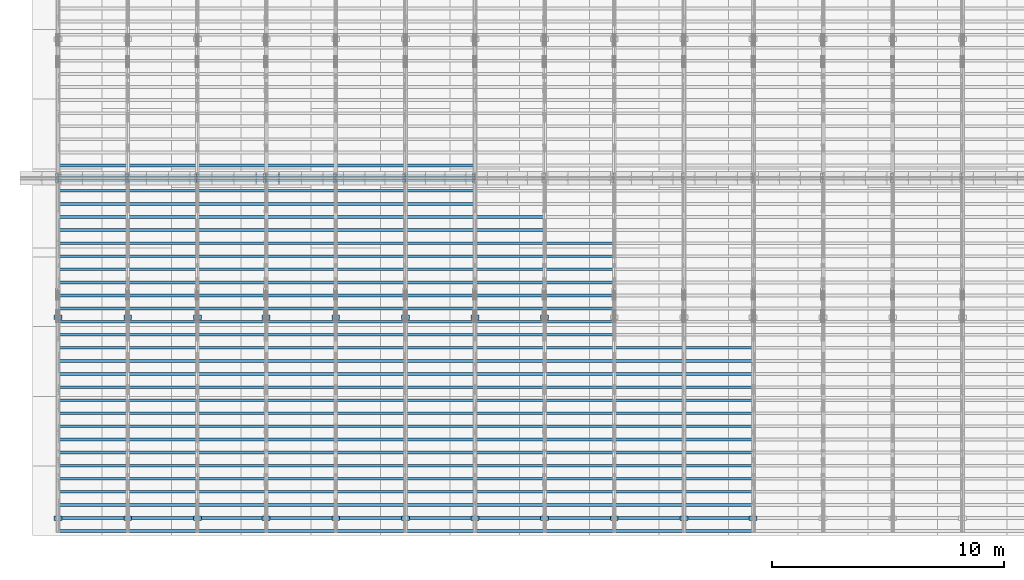
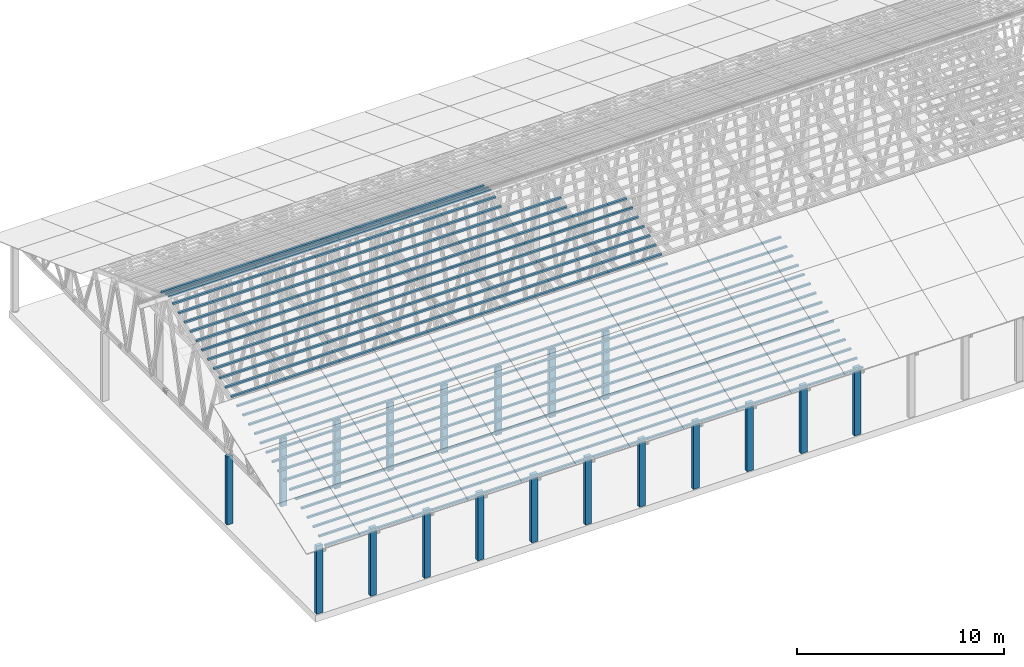
# One storey, part 1 of 189: 277 columns.
"""IFC2X3 building model written with IfcOpenShell, lengths in millimetres."""

from ifc_helpers import new_model, entity, si_unit, converted_unit, derived_unit, direction, frame, frame_2d, origin, origin_2d_with_axis, place, context, subcontext, project, spatial, rectangle, extrude, boolean, source, transform, mapped, material, type_object, type_shapes, element, save


model = new_model("IFC2X3")

# Units and contexts
model_context = context("Model", 3, precision=0.01, world=origin(), true_north=direction((6.12303176911189e-17, 1.0)))
body_context = subcontext(model_context, "Body", "Model", "MODEL_VIEW")
ifc_project = project(units=[si_unit("LENGTHUNIT", "METRE", prefix="MILLI"), si_unit("AREAUNIT", "SQUARE_METRE"), si_unit("VOLUMEUNIT", "CUBIC_METRE"), converted_unit("PLANEANGLEUNIT", "DEGREE", entity("IfcRatioMeasure", 0.0174532925199433), si_unit("PLANEANGLEUNIT", "RADIAN"), dimensions=[0, 0, 0, 0, 0, 0, 0]), si_unit("MASSUNIT", "GRAM", prefix="KILO"), derived_unit("MASSDENSITYUNIT", [(si_unit("MASSUNIT", "GRAM", prefix="KILO"), 1), (si_unit("LENGTHUNIT", "METRE"), -3)]), si_unit("TIMEUNIT", "SECOND"), si_unit("FREQUENCYUNIT", "HERTZ"), si_unit("THERMODYNAMICTEMPERATUREUNIT", "DEGREE_CELSIUS"), derived_unit("THERMALTRANSMITTANCEUNIT", [(si_unit("MASSUNIT", "GRAM", prefix="KILO"), 1), (si_unit("THERMODYNAMICTEMPERATUREUNIT", "KELVIN"), -1), (si_unit("TIMEUNIT", "SECOND"), -3)]), derived_unit("VOLUMETRICFLOWRATEUNIT", [(si_unit("LENGTHUNIT", "METRE"), 3), (si_unit("TIMEUNIT", "SECOND"), -1)]), si_unit("ELECTRICCURRENTUNIT", "AMPERE"), si_unit("ELECTRICVOLTAGEUNIT", "VOLT"), si_unit("POWERUNIT", "WATT"), si_unit("FORCEUNIT", "NEWTON"), si_unit("ILLUMINANCEUNIT", "LUX"), si_unit("LUMINOUSFLUXUNIT", "LUMEN"), si_unit("LUMINOUSINTENSITYUNIT", "CANDELA"), derived_unit("USERDEFINED", [(si_unit("MASSUNIT", "GRAM", prefix="KILO"), -1), (si_unit("LENGTHUNIT", "METRE"), -2), (si_unit("TIMEUNIT", "SECOND"), 3), (si_unit("LUMINOUSFLUXUNIT", "LUMEN"), 1)]), derived_unit("LINEARVELOCITYUNIT", [(si_unit("LENGTHUNIT", "METRE"), 1), (si_unit("TIMEUNIT", "SECOND"), -1)]), si_unit("PRESSUREUNIT", "PASCAL"), derived_unit("USERDEFINED", [(si_unit("LENGTHUNIT", "METRE"), -2), (si_unit("MASSUNIT", "GRAM", prefix="KILO"), 1), (si_unit("TIMEUNIT", "SECOND"), -2)])], contexts=[model_context])

# Site, building, storey
site_placement = place(None, origin())
site = spatial("IfcSite", under=ifc_project, at=site_placement, CompositionType="ELEMENT")
building_placement = place(site_placement, origin())
building = spatial("IfcBuilding", under=site, at=building_placement, CompositionType="ELEMENT")
storey_placement = place(building_placement, origin())
storey = spatial("IfcBuildingStorey", under=building, at=storey_placement, Name="Default", CompositionType="ELEMENT", Elevation=0.0)

# Columns
ifc_material_1 = material(Name="2")
column_type_1 = type_object("IfcColumnType", Name="100x70", PredefinedType="COLUMN")
shared_shape_1 = source(origin(), body_context, "Body", "CSG", [
    boolean("DIFFERENCE", extrude(rectangle(XDim=2998.26294985256, YDim=117.910672112436, at=frame_2d((0.0, -7.105427357601e-15), x_axis=(1.0, 0.0))), frame((1499.13147492628, 146.833369190677, -28.6286403914047)), (0.0, 0.0, 1.0), 99.9804977897746), extrude(rectangle(XDim=70.0000000018648, YDim=100.00000000027, at=frame_2d((3.5527136788005e-15, 3.5527136788005e-15), x_axis=(0.0, 1.0))), frame((2998.26294985256, 146.833369190677, 21.3616085034827), z_axis=(1.0, 0.0, 0.0), x_axis=(0.0, 0.939692620784201, -0.34202014333036)), (0.0, 0.0, -1.0), 2998.26294985256)),
])
type_shapes(column_type_1, [shared_shape_1])
for number, where, name in (
    (1, (15233.4741002949, 15149.371280703, 5585.64342365955), "H_28_35_gradi:100x70"),
    (2, (15233.4741002949, 14712.1220107287, 5744.78914288479), "H_28_35_gradi:100x70"),
    (3, (12231.7370501475, 15149.371280703, 5585.64342365955), "H_28_35_gradi:100x70"),
    (4, (12231.7370501475, 14712.1220107288, 5744.78914288479), "H_28_35_gradi:100x70"),
    (5, (9233.47410029491, 15149.371280703, 5585.64342365955), "H_28_35_gradi:100x70"),
    (6, (9233.47410029491, 14712.1220107288, 5744.78914288479), "H_28_35_gradi:100x70"),
    (7, (6235.21115044234, 15149.371280703, 5585.64342365955), "H_28_35_gradi:100x70"),
    (8, (6235.21115044234, 14712.1220107288, 5744.78914288479), "H_28_35_gradi:100x70"),
    (9, (3266.73705014749, 15149.371280703, 5585.64342365955), "H_28_35_gradi:100x70"),
    (10, (3266.73705014749, 14712.1220107288, 5744.78914288479), "H_28_35_gradi:100x70"),
    (11, (268.474100294913, 15149.371280703, 5585.64342365955), "H_28_35_gradi:100x70"),
    (12, (268.474100294913, 14712.1220107288, 5744.78914288479), "H_28_35_gradi:100x70"),
):
    element("IfcColumn", number, at=place(storey_placement, frame(where)), inside=storey, type_object=column_type_1, material=ifc_material_1, Name=name, ObjectType="H_28_35_gradi:100x70", context=body_context, shape_type="MappedRepresentation", body=[
        mapped(shared_shape_1, transform((0.0, 0.0, 0.0), scale=1.0)),
    ])
column_type_2 = type_object("IfcColumnType", Name="100x70", PredefinedType="COLUMN")
shared_shape_2 = source(origin(), body_context, "Body", "CSG", [
    boolean("DIFFERENCE", extrude(rectangle(XDim=2998.26294985257, YDim=117.910672112436, at=frame_2d((0.0, 7.105427357601e-15), x_axis=(1.0, 0.0))), frame((1499.13147492629, -146.833369190677, -28.6286403914047)), (0.0, 0.0, 1.0), 99.9804977897746), extrude(rectangle(XDim=70.0000000018648, YDim=100.00000000027, at=frame_2d((3.5527136788005e-15, 3.5527136788005e-15), x_axis=(0.0, 1.0))), frame((0.0, -146.833369190677, 21.3616085034827), z_axis=(-1.0, 0.0, 0.0), x_axis=(0.0, -0.939692620784201, -0.34202014333036)), (0.0, 0.0, -1.0), 2998.26294985257)),
])
type_shapes(column_type_2, [shared_shape_2])
for number, where, name in (
    (13, (27231.7370501474, 255.239495234009, 455.341273776488), "H_28_35_gradi:100x70"),
    (14, (27231.7370501474, 819.055067706269, 660.553359769929), "H_28_35_gradi:100x70"),
    (15, (27231.7370501474, 1382.87064017781, 865.765445765329), "H_28_35_gradi:100x70"),
    (16, (27231.7370501474, 1946.68621264935, 1070.97753176073), "H_28_35_gradi:100x70"),
    (17, (27231.7370501474, 2510.50178512089, 1276.18961775613), "H_28_35_gradi:100x70"),
    (18, (27231.7370501474, 3074.31735759244, 1481.40170375153), "H_28_35_gradi:100x70"),
    (19, (27231.7370501474, 3638.13293006398, 1686.61378974693), "H_28_35_gradi:100x70"),
    (20, (27231.7370501474, 4201.94850253552, 1891.82587574233), "H_28_35_gradi:100x70"),
    (21, (27231.7370501474, 4765.76407500707, 2097.03796173773), "H_28_35_gradi:100x70"),
    (22, (27231.7370501474, 5329.57964747861, 2302.25004773314), "H_28_35_gradi:100x70"),
    (23, (27231.7370501474, 5893.39521995016, 2507.46213372854), "H_28_35_gradi:100x70"),
    (24, (27231.7370501474, 6457.2107924217, 2712.67421972394), "H_28_35_gradi:100x70"),
    (25, (27231.7370501474, 7021.02636489325, 2917.88630571934), "H_28_35_gradi:100x70"),
    (26, (27231.7370501474, 7584.84193736479, 3123.09839171474), "H_28_35_gradi:100x70"),
    (27, (27231.7370501474, -308.576077237536, 250.129187781088), "H_28_35_gradi:100x70"),
    (28, (24233.4741002948, 255.239495234019, 455.341273776488), "H_28_35_gradi:100x70"),
    (29, (24233.4741002948, 819.055067706279, 660.553359769929), "H_28_35_gradi:100x70"),
    (30, (24233.4741002948, 1382.87064017782, 865.765445765329), "H_28_35_gradi:100x70"),
    (31, (24233.4741002948, 1946.68621264936, 1070.97753176073), "H_28_35_gradi:100x70"),
    (32, (24233.4741002949, 2510.5017851209, 1276.18961775613), "H_28_35_gradi:100x70"),
    (33, (24233.4741002949, 3074.31735759245, 1481.40170375153), "H_28_35_gradi:100x70"),
    (34, (24233.4741002949, 3638.13293006399, 1686.61378974693), "H_28_35_gradi:100x70"),
    (35, (24233.4741002949, 4201.94850253553, 1891.82587574233), "H_28_35_gradi:100x70"),
    (36, (24233.4741002949, 4765.76407500708, 2097.03796173773), "H_28_35_gradi:100x70"),
    (37, (24233.4741002949, 5329.57964747862, 2302.25004773314), "H_28_35_gradi:100x70"),
    (38, (24233.4741002949, 5893.39521995016, 2507.46213372854), "H_28_35_gradi:100x70"),
    (39, (24233.4741002949, 6457.21079242171, 2712.67421972394), "H_28_35_gradi:100x70"),
    (40, (24233.4741002949, 7021.02636489326, 2917.88630571934), "H_28_35_gradi:100x70"),
    (41, (24233.4741002949, 7584.8419373648, 3123.09839171474), "H_28_35_gradi:100x70"),
    (42, (24233.4741002948, -308.576077237526, 250.129187781088), "H_28_35_gradi:100x70"),
    (43, (21235.2111504423, 255.239495234028, 455.341273776488), "H_28_35_gradi:100x70"),
    (44, (21235.2111504423, 819.055067706288, 660.553359769929), "H_28_35_gradi:100x70"),
    (45, (21235.2111504423, 1382.87064017783, 865.765445765329), "H_28_35_gradi:100x70"),
    (46, (21235.2111504423, 1946.68621264937, 1070.97753176073), "H_28_35_gradi:100x70"),
    (47, (21235.2111504423, 2510.50178512091, 1276.18961775613), "H_28_35_gradi:100x70"),
    (48, (21235.2111504423, 3074.31735759246, 1481.40170375153), "H_28_35_gradi:100x70"),
    (49, (21235.2111504423, 3638.132930064, 1686.61378974693), "H_28_35_gradi:100x70"),
    (50, (21235.2111504423, 4201.94850253554, 1891.82587574233), "H_28_35_gradi:100x70"),
    (51, (21235.2111504423, 4765.76407500709, 2097.03796173773), "H_28_35_gradi:100x70"),
    (52, (21235.2111504423, 5329.57964747863, 2302.25004773314), "H_28_35_gradi:100x70"),
    (53, (21235.2111504423, 5893.39521995017, 2507.46213372854), "H_28_35_gradi:100x70"),
    (54, (21235.2111504423, 6457.21079242172, 2712.67421972394), "H_28_35_gradi:100x70"),
    (55, (21235.2111504423, 7021.02636489326, 2917.88630571934), "H_28_35_gradi:100x70"),
    (56, (21235.2111504423, 7584.84193736481, 3123.09839171474), "H_28_35_gradi:100x70"),
    (57, (21235.2111504423, 8148.65750983635, 3328.31047771014), "H_28_35_gradi:100x70"),
    (58, (21235.2111504423, 8712.4730823079, 3533.52256370554), "H_28_35_gradi:100x70"),
    (59, (21235.2111504423, 9276.28865477944, 3738.73464970094), "H_28_35_gradi:100x70"),
    (60, (21235.2111504423, 9840.10422725098, 3943.94673569634), "H_28_35_gradi:100x70"),
    (61, (21235.2111504423, 10403.9197997225, 4149.15882169174), "H_28_35_gradi:100x70"),
    (62, (21235.2111504423, 10967.7353721941, 4354.37090768715), "H_28_35_gradi:100x70"),
    (63, (21235.2111504423, 11531.5509446656, 4559.58299368255), "H_28_35_gradi:100x70"),
    (64, (21235.2111504423, 12095.3665171372, 4764.79507967795), "H_28_35_gradi:100x70"),
    (65, (21235.2111504423, -308.576077237516, 250.129187781088), "H_28_35_gradi:100x70"),
    (66, (18231.7370501474, 255.239495234038, 455.341273776488), "H_28_35_gradi:100x70"),
    (67, (18231.7370501474, 819.055067706298, 660.553359769929), "H_28_35_gradi:100x70"),
    (68, (18231.7370501474, 1382.87064017784, 865.765445765329), "H_28_35_gradi:100x70"),
    (69, (18231.7370501474, 1946.68621264938, 1070.97753176073), "H_28_35_gradi:100x70"),
    (70, (18231.7370501474, 2510.50178512092, 1276.18961775613), "H_28_35_gradi:100x70"),
    (71, (18231.7370501474, 3074.31735759247, 1481.40170375153), "H_28_35_gradi:100x70"),
    (72, (18231.7370501474, 3638.13293006401, 1686.61378974693), "H_28_35_gradi:100x70"),
    (73, (18231.7370501474, 4201.94850253555, 1891.82587574233), "H_28_35_gradi:100x70"),
    (74, (18231.7370501474, 4765.7640750071, 2097.03796173773), "H_28_35_gradi:100x70"),
    (75, (18231.7370501474, 5329.57964747864, 2302.25004773314), "H_28_35_gradi:100x70"),
    (76, (18231.7370501474, 5893.39521995018, 2507.46213372854), "H_28_35_gradi:100x70"),
    (77, (18231.7370501474, 6457.21079242173, 2712.67421972394), "H_28_35_gradi:100x70"),
    (78, (18231.7370501474, 7021.02636489327, 2917.88630571934), "H_28_35_gradi:100x70"),
    (79, (18231.7370501474, 7584.84193736482, 3123.09839171474), "H_28_35_gradi:100x70"),
    (80, (18231.7370501475, 8148.65750983636, 3328.31047771014), "H_28_35_gradi:100x70"),
    (81, (18231.7370501475, 8712.47308230791, 3533.52256370554), "H_28_35_gradi:100x70"),
    (82, (18231.7370501475, 9276.28865477945, 3738.73464970094), "H_28_35_gradi:100x70"),
    (83, (18231.7370501475, 9840.10422725099, 3943.94673569634), "H_28_35_gradi:100x70"),
    (84, (18231.7370501475, 10403.9197997225, 4149.15882169174), "H_28_35_gradi:100x70"),
    (85, (18231.7370501475, 10967.7353721941, 4354.37090768715), "H_28_35_gradi:100x70"),
    (86, (18231.7370501475, 11531.5509446656, 4559.58299368255), "H_28_35_gradi:100x70"),
    (87, (18231.7370501475, 12095.3665171372, 4764.79507967795), "H_28_35_gradi:100x70"),
    (88, (18231.7370501475, 12659.1820896087, 4970.00716567335), "H_28_35_gradi:100x70"),
    (89, (18231.7370501475, 13222.9976620803, 5175.21925166875), "H_28_35_gradi:100x70"),
    (90, (18231.7370501474, -308.576077237507, 250.129187781088), "H_28_35_gradi:100x70"),
    (91, (15233.4741002948, 255.239495234048, 455.341273776488), "H_28_35_gradi:100x70"),
    (92, (15233.4741002948, 819.055067706308, 660.553359769929), "H_28_35_gradi:100x70"),
    (93, (15233.4741002948, 1382.87064017785, 865.765445765329), "H_28_35_gradi:100x70"),
    (94, (15233.4741002948, 1946.68621264939, 1070.97753176073), "H_28_35_gradi:100x70"),
    (95, (15233.4741002949, 2510.50178512093, 1276.18961775613), "H_28_35_gradi:100x70"),
    (96, (15233.4741002949, 3074.31735759248, 1481.40170375153), "H_28_35_gradi:100x70"),
    (97, (15233.4741002949, 3638.13293006402, 1686.61378974693), "H_28_35_gradi:100x70"),
    (98, (15233.4741002949, 4201.94850253556, 1891.82587574233), "H_28_35_gradi:100x70"),
    (99, (15233.4741002949, 4765.76407500711, 2097.03796173773), "H_28_35_gradi:100x70"),
    (100, (15233.4741002949, 5329.57964747865, 2302.25004773314), "H_28_35_gradi:100x70"),
    (101, (15233.4741002949, 5893.39521995019, 2507.46213372854), "H_28_35_gradi:100x70"),
    (102, (15233.4741002949, 6457.21079242174, 2712.67421972394), "H_28_35_gradi:100x70"),
    (103, (15233.4741002949, 7021.02636489328, 2917.88630571934), "H_28_35_gradi:100x70"),
    (104, (15233.4741002949, 7584.84193736483, 3123.09839171474), "H_28_35_gradi:100x70"),
    (105, (15233.4741002949, 8148.65750983637, 3328.31047771014), "H_28_35_gradi:100x70"),
    (106, (15233.4741002949, 8712.47308230792, 3533.52256370554), "H_28_35_gradi:100x70"),
    (107, (15233.4741002949, 9276.28865477946, 3738.73464970094), "H_28_35_gradi:100x70"),
    (108, (15233.4741002949, 9840.104227251, 3943.94673569634), "H_28_35_gradi:100x70"),
    (109, (15233.4741002949, 10403.9197997225, 4149.15882169174), "H_28_35_gradi:100x70"),
    (110, (15233.4741002949, 10967.7353721941, 4354.37090768715), "H_28_35_gradi:100x70"),
    (111, (15233.4741002949, 11531.5509446656, 4559.58299368255), "H_28_35_gradi:100x70"),
    (112, (15233.4741002949, 12095.3665171372, 4764.79507967795), "H_28_35_gradi:100x70"),
    (113, (15233.4741002949, 12659.1820896087, 4970.00716567335), "H_28_35_gradi:100x70"),
    (114, (15233.4741002949, 13222.9976620803, 5175.21925166875), "H_28_35_gradi:100x70"),
    (115, (15233.4741002949, 13786.8132345518, 5380.43133766415), "H_28_35_gradi:100x70"),
    (116, (15233.4741002949, 14350.6288070234, 5585.64342365955), "H_28_35_gradi:100x70"),
    (117, (15233.4741002949, 14787.8780769976, 5744.78914288479), "H_28_35_gradi:100x70"),
    (118, (15233.4741002948, -308.576077237497, 250.129187781088), "H_28_35_gradi:100x70"),
    (119, (12231.7370501474, 255.239495234057, 455.341273776488), "H_28_35_gradi:100x70"),
    (120, (12231.7370501474, 819.055067706318, 660.553359769929), "H_28_35_gradi:100x70"),
    (121, (12231.7370501474, 1382.87064017786, 865.765445765329), "H_28_35_gradi:100x70"),
    (122, (12231.7370501474, 1946.6862126494, 1070.97753176073), "H_28_35_gradi:100x70"),
    (123, (12231.7370501474, 2510.50178512094, 1276.18961775613), "H_28_35_gradi:100x70"),
    (124, (12231.7370501474, 3074.31735759249, 1481.40170375153), "H_28_35_gradi:100x70"),
    (125, (12231.7370501474, 3638.13293006403, 1686.61378974693), "H_28_35_gradi:100x70"),
    (126, (12231.7370501474, 4201.94850253557, 1891.82587574233), "H_28_35_gradi:100x70"),
    (127, (12231.7370501474, 4765.76407500712, 2097.03796173773), "H_28_35_gradi:100x70"),
    (128, (12231.7370501474, 5329.57964747866, 2302.25004773314), "H_28_35_gradi:100x70"),
    (129, (12231.7370501474, 5893.3952199502, 2507.46213372854), "H_28_35_gradi:100x70"),
    (130, (12231.7370501475, 6457.21079242175, 2712.67421972394), "H_28_35_gradi:100x70"),
    (131, (12231.7370501475, 7021.02636489329, 2917.88630571934), "H_28_35_gradi:100x70"),
    (132, (12231.7370501475, 7584.84193736484, 3123.09839171474), "H_28_35_gradi:100x70"),
    (133, (12231.7370501475, 8148.65750983638, 3328.31047771014), "H_28_35_gradi:100x70"),
    (134, (12231.7370501475, 8712.47308230793, 3533.52256370554), "H_28_35_gradi:100x70"),
    (135, (12231.7370501475, 9276.28865477947, 3738.73464970094), "H_28_35_gradi:100x70"),
    (136, (12231.7370501475, 9840.104227251, 3943.94673569634), "H_28_35_gradi:100x70"),
    (137, (12231.7370501475, 10403.9197997225, 4149.15882169174), "H_28_35_gradi:100x70"),
    (138, (12231.7370501475, 10967.7353721941, 4354.37090768715), "H_28_35_gradi:100x70"),
    (139, (12231.7370501475, 11531.5509446656, 4559.58299368255), "H_28_35_gradi:100x70"),
    (140, (12231.7370501475, 12095.3665171372, 4764.79507967795), "H_28_35_gradi:100x70"),
    (141, (12231.7370501475, 12659.1820896087, 4970.00716567335), "H_28_35_gradi:100x70"),
    (142, (12231.7370501475, 13222.9976620803, 5175.21925166875), "H_28_35_gradi:100x70"),
    (143, (12231.7370501475, 13786.8132345518, 5380.43133766415), "H_28_35_gradi:100x70"),
    (144, (12231.7370501475, 14350.6288070234, 5585.64342365955), "H_28_35_gradi:100x70"),
    (145, (12231.7370501475, 14787.8780769976, 5744.78914288479), "H_28_35_gradi:100x70"),
    (146, (12231.7370501474, -308.576077237487, 250.129187781088), "H_28_35_gradi:100x70"),
    (147, (9233.47410029485, 255.239495234067, 455.341273776488), "H_28_35_gradi:100x70"),
    (148, (9233.47410029485, 819.055067706327, 660.553359769929), "H_28_35_gradi:100x70"),
    (149, (9233.47410029485, 1382.87064017787, 865.765445765329), "H_28_35_gradi:100x70"),
    (150, (9233.47410029485, 1946.68621264941, 1070.97753176073), "H_28_35_gradi:100x70"),
    (151, (9233.47410029486, 2510.50178512095, 1276.18961775613), "H_28_35_gradi:100x70"),
    (152, (9233.47410029486, 3074.3173575925, 1481.40170375153), "H_28_35_gradi:100x70"),
    (153, (9233.47410029486, 3638.13293006404, 1686.61378974693), "H_28_35_gradi:100x70"),
    (154, (9233.47410029487, 4201.94850253558, 1891.82587574233), "H_28_35_gradi:100x70"),
    (155, (9233.47410029487, 4765.76407500713, 2097.03796173773), "H_28_35_gradi:100x70"),
    (156, (9233.47410029487, 5329.57964747867, 2302.25004773314), "H_28_35_gradi:100x70"),
    (157, (9233.47410029487, 5893.39521995021, 2507.46213372854), "H_28_35_gradi:100x70"),
    (158, (9233.47410029488, 6457.21079242176, 2712.67421972394), "H_28_35_gradi:100x70"),
    (159, (9233.47410029488, 7021.0263648933, 2917.88630571934), "H_28_35_gradi:100x70"),
    (160, (9233.47410029488, 7584.84193736485, 3123.09839171474), "H_28_35_gradi:100x70"),
    (161, (9233.47410029489, 8148.65750983639, 3328.31047771014), "H_28_35_gradi:100x70"),
    (162, (9233.47410029489, 8712.47308230794, 3533.52256370554), "H_28_35_gradi:100x70"),
    (163, (9233.47410029489, 9276.28865477948, 3738.73464970094), "H_28_35_gradi:100x70"),
    (164, (9233.47410029489, 9840.10422725101, 3943.94673569634), "H_28_35_gradi:100x70"),
    (165, (9233.4741002949, 10403.9197997226, 4149.15882169174), "H_28_35_gradi:100x70"),
    (166, (9233.4741002949, 10967.7353721941, 4354.37090768715), "H_28_35_gradi:100x70"),
    (167, (9233.4741002949, 11531.5509446656, 4559.58299368255), "H_28_35_gradi:100x70"),
    (168, (9233.4741002949, 12095.3665171372, 4764.79507967795), "H_28_35_gradi:100x70"),
    (169, (9233.4741002949, 12659.1820896087, 4970.00716567335), "H_28_35_gradi:100x70"),
    (170, (9233.4741002949, 13222.9976620803, 5175.21925166875), "H_28_35_gradi:100x70"),
    (171, (9233.4741002949, 13786.8132345518, 5380.43133766415), "H_28_35_gradi:100x70"),
    (172, (9233.47410029491, 14350.6288070234, 5585.64342365955), "H_28_35_gradi:100x70"),
    (173, (9233.47410029491, 14787.8780769976, 5744.78914288479), "H_28_35_gradi:100x70"),
    (174, (9233.47410029485, -308.576077237478, 250.129187781088), "H_28_35_gradi:100x70"),
    (175, (6235.21115044228, 255.239495234077, 455.341273776488), "H_28_35_gradi:100x70"),
    (176, (6235.21115044228, 819.055067706337, 660.553359769929), "H_28_35_gradi:100x70"),
    (177, (6235.21115044228, 1382.87064017788, 865.765445765329), "H_28_35_gradi:100x70"),
    (178, (6235.21115044228, 1946.68621264942, 1070.97753176073), "H_28_35_gradi:100x70"),
    (179, (6235.21115044229, 2510.50178512096, 1276.18961775613), "H_28_35_gradi:100x70"),
    (180, (6235.21115044229, 3074.31735759251, 1481.40170375153), "H_28_35_gradi:100x70"),
    (181, (6235.21115044229, 3638.13293006405, 1686.61378974693), "H_28_35_gradi:100x70"),
    (182, (6235.2111504423, 4201.94850253559, 1891.82587574233), "H_28_35_gradi:100x70"),
    (183, (6235.2111504423, 4765.76407500714, 2097.03796173773), "H_28_35_gradi:100x70"),
    (184, (6235.2111504423, 5329.57964747868, 2302.25004773314), "H_28_35_gradi:100x70"),
    (185, (6235.2111504423, 5893.39521995022, 2507.46213372854), "H_28_35_gradi:100x70"),
    (186, (6235.21115044231, 6457.21079242177, 2712.67421972394), "H_28_35_gradi:100x70"),
    (187, (6235.21115044231, 7021.02636489331, 2917.88630571934), "H_28_35_gradi:100x70"),
    (188, (6235.21115044231, 7584.84193736486, 3123.09839171474), "H_28_35_gradi:100x70"),
    (189, (6235.21115044231, 8148.6575098364, 3328.31047771014), "H_28_35_gradi:100x70"),
    (190, (6235.21115044231, 8712.47308230795, 3533.52256370554), "H_28_35_gradi:100x70"),
    (191, (6235.21115044231, 9276.28865477949, 3738.73464970094), "H_28_35_gradi:100x70"),
    (192, (6235.21115044231, 9840.10422725102, 3943.94673569634), "H_28_35_gradi:100x70"),
    (193, (6235.21115044232, 10403.9197997226, 4149.15882169174), "H_28_35_gradi:100x70"),
    (194, (6235.21115044232, 10967.7353721941, 4354.37090768715), "H_28_35_gradi:100x70"),
    (195, (6235.21115044232, 11531.5509446657, 4559.58299368255), "H_28_35_gradi:100x70"),
    (196, (6235.21115044232, 12095.3665171372, 4764.79507967795), "H_28_35_gradi:100x70"),
    (197, (6235.21115044233, 12659.1820896087, 4970.00716567335), "H_28_35_gradi:100x70"),
    (198, (6235.21115044233, 13222.9976620803, 5175.21925166875), "H_28_35_gradi:100x70"),
    (199, (6235.21115044233, 13786.8132345518, 5380.43133766415), "H_28_35_gradi:100x70"),
    (200, (6235.21115044234, 14350.6288070234, 5585.64342365955), "H_28_35_gradi:100x70"),
    (201, (6235.21115044234, 14787.8780769976, 5744.78914288479), "H_28_35_gradi:100x70"),
    (202, (6235.21115044228, -308.576077237468, 250.129187781088), "H_28_35_gradi:100x70"),
    (203, (3266.73705014743, 255.239495234086, 455.341273776488), "H_28_35_gradi:100x70"),
    (204, (3266.73705014743, 819.055067706347, 660.553359769929), "H_28_35_gradi:100x70"),
    (205, (3266.73705014743, 1382.87064017789, 865.765445765329), "H_28_35_gradi:100x70"),
    (206, (3266.73705014743, 1946.68621264943, 1070.97753176073), "H_28_35_gradi:100x70"),
    (207, (3266.73705014744, 2510.50178512097, 1276.18961775613), "H_28_35_gradi:100x70"),
    (208, (3266.73705014744, 3074.31735759252, 1481.40170375153), "H_28_35_gradi:100x70"),
    (209, (3266.73705014744, 3638.13293006406, 1686.61378974693), "H_28_35_gradi:100x70"),
    (210, (3266.73705014744, 4201.9485025356, 1891.82587574233), "H_28_35_gradi:100x70"),
    (211, (3266.73705014744, 4765.76407500715, 2097.03796173773), "H_28_35_gradi:100x70"),
    (212, (3266.73705014744, 5329.57964747869, 2302.25004773314), "H_28_35_gradi:100x70"),
    (213, (3266.73705014744, 5893.39521995023, 2507.46213372854), "H_28_35_gradi:100x70"),
    (214, (3266.73705014745, 6457.21079242178, 2712.67421972394), "H_28_35_gradi:100x70"),
    (215, (3266.73705014745, 7021.02636489332, 2917.88630571934), "H_28_35_gradi:100x70"),
    (216, (3266.73705014745, 7584.84193736487, 3123.09839171474), "H_28_35_gradi:100x70"),
    (217, (3266.73705014746, 8148.65750983641, 3328.31047771014), "H_28_35_gradi:100x70"),
    (218, (3266.73705014746, 8712.47308230796, 3533.52256370554), "H_28_35_gradi:100x70"),
    (219, (3266.73705014746, 9276.2886547795, 3738.73464970094), "H_28_35_gradi:100x70"),
    (220, (3266.73705014746, 9840.10422725103, 3943.94673569634), "H_28_35_gradi:100x70"),
    (221, (3266.73705014747, 10403.9197997226, 4149.15882169174), "H_28_35_gradi:100x70"),
    (222, (3266.73705014747, 10967.7353721941, 4354.37090768715), "H_28_35_gradi:100x70"),
    (223, (3266.73705014747, 11531.5509446657, 4559.58299368255), "H_28_35_gradi:100x70"),
    (224, (3266.73705014747, 12095.3665171372, 4764.79507967795), "H_28_35_gradi:100x70"),
    (225, (3266.73705014748, 12659.1820896088, 4970.00716567335), "H_28_35_gradi:100x70"),
    (226, (3266.73705014748, 13222.9976620803, 5175.21925166875), "H_28_35_gradi:100x70"),
    (227, (3266.73705014748, 13786.8132345518, 5380.43133766415), "H_28_35_gradi:100x70"),
    (228, (3266.73705014749, 14350.6288070234, 5585.64342365955), "H_28_35_gradi:100x70"),
    (229, (3266.73705014749, 14787.8780769976, 5744.78914288479), "H_28_35_gradi:100x70"),
    (230, (3266.73705014743, -308.576077237458, 250.129187781088), "H_28_35_gradi:100x70"),
    (231, (268.474100294853, 255.239495234096, 455.341273776488), "H_28_35_gradi:100x70"),
    (232, (268.474100294853, 819.055067706356, 660.553359769929), "H_28_35_gradi:100x70"),
    (233, (268.474100294853, 1382.8706401779, 865.765445765329), "H_28_35_gradi:100x70"),
    (234, (268.474100294853, 1946.68621264944, 1070.97753176073), "H_28_35_gradi:100x70"),
    (235, (268.474100294861, 2510.50178512098, 1276.18961775613), "H_28_35_gradi:100x70"),
    (236, (268.474100294861, 3074.31735759253, 1481.40170375153), "H_28_35_gradi:100x70"),
    (237, (268.474100294861, 3638.13293006407, 1686.61378974693), "H_28_35_gradi:100x70"),
    (238, (268.47410029487, 4201.94850253561, 1891.82587574233), "H_28_35_gradi:100x70"),
    (239, (268.47410029487, 4765.76407500716, 2097.03796173773), "H_28_35_gradi:100x70"),
    (240, (268.47410029487, 5329.5796474787, 2302.25004773314), "H_28_35_gradi:100x70"),
    (241, (268.47410029487, 5893.39521995024, 2507.46213372854), "H_28_35_gradi:100x70"),
    (242, (268.474100294879, 6457.21079242179, 2712.67421972394), "H_28_35_gradi:100x70"),
    (243, (268.474100294879, 7021.02636489333, 2917.88630571934), "H_28_35_gradi:100x70"),
    (244, (268.474100294879, 7584.84193736488, 3123.09839171474), "H_28_35_gradi:100x70"),
    (245, (268.474100294887, 8148.65750983642, 3328.31047771014), "H_28_35_gradi:100x70"),
    (246, (268.474100294887, 8712.47308230797, 3533.52256370554), "H_28_35_gradi:100x70"),
    (247, (268.474100294887, 9276.28865477951, 3738.73464970094), "H_28_35_gradi:100x70"),
    (248, (268.474100294887, 9840.10422725104, 3943.94673569634), "H_28_35_gradi:100x70"),
    (249, (268.474100294896, 10403.9197997226, 4149.15882169174), "H_28_35_gradi:100x70"),
    (250, (268.474100294896, 10967.7353721941, 4354.37090768715), "H_28_35_gradi:100x70"),
    (251, (268.474100294896, 11531.5509446657, 4559.58299368255), "H_28_35_gradi:100x70"),
    (252, (268.474100294896, 12095.3665171372, 4764.79507967795), "H_28_35_gradi:100x70"),
    (253, (268.474100294905, 12659.1820896088, 4970.00716567335), "H_28_35_gradi:100x70"),
    (254, (268.474100294905, 13222.9976620803, 5175.21925166875), "H_28_35_gradi:100x70"),
    (255, (268.474100294905, 13786.8132345519, 5380.43133766415), "H_28_35_gradi:100x70"),
    (256, (268.474100294913, 14350.6288070234, 5585.64342365955), "H_28_35_gradi:100x70"),
    (257, (268.474100294913, 14787.8780769976, 5744.78914288479), "H_28_35_gradi:100x70"),
    (258, (268.474100294853, -308.576077237449, 250.129187781088), "H_28_35_gradi:100x70"),
):
    element("IfcColumn", number, at=place(storey_placement, frame(where)), inside=storey, type_object=column_type_2, material=ifc_material_1, Name=name, ObjectType="H_28_35_gradi:100x70", context=body_context, shape_type="MappedRepresentation", body=[
        mapped(shared_shape_2, transform((0.0, 0.0, 0.0), scale=1.0)),
    ])
ifc_material_2 = material()
column_type_3 = type_object("IfcColumnType", Name="200x200", PredefinedType="COLUMN")
shared_shape_3 = source(origin(), body_context, "Body", "SweptSolid", [
    extrude(rectangle(XDim=339.999999999998, YDim=200.000000000004, at=origin_2d_with_axis()), frame((100.0, 280.0, -4000.0), z_axis=(0.0, 0.0, 1.0), x_axis=(0.0, -1.0, 0.0)), (0.0, 0.0, 1.0), 4000.0),
])
type_shapes(column_type_3, [shared_shape_3])
for number, where, z_axis, x_axis, name in (
    (259, (30490.0, 0.0, 0.0), (0.0, 0.0, 1.0), (0.0, 1.0, 0.0), "V:200x200"),
    (260, (27510.0, 0.0, 0.0), (0.0, 0.0, 1.0), (0.0, 1.0, 0.0), "V:200x200"),
    (261, (24510.0, 0.0, 0.0), (0.0, 0.0, 1.0), (0.0, 1.0, 0.0), "V:200x200"),
    (262, (21510.0, 0.0, 0.0), (0.0, 0.0, 1.0), (0.0, 1.0, 0.0), "V:200x200"),
    (263, (18510.0, 0.0, 0.0), (0.0, 0.0, 1.0), (0.0, 1.0, 0.0), "V:200x200"),
    (264, (15510.0, 0.0, 0.0), (0.0, 0.0, 1.0), (0.0, 1.0, 0.0), "V:200x200"),
    (265, (12510.0, 0.0, 0.0), (0.0, 0.0, 1.0), (0.0, 1.0, 0.0), "V:200x200"),
    (266, (9510.0, 0.0, 0.0), (0.0, 0.0, 1.0), (0.0, 1.0, 0.0), "V:200x200"),
    (267, (6545.0, 0.0, 0.0), (0.0, 0.0, 1.0), (0.0, 1.0, 0.0), "V:200x200"),
    (268, (3545.0, 0.0, 0.0), (0.0, 0.0, 1.0), (0.0, 1.0, 0.0), "V:200x200"),
    (269, (545.0, 0.0, 0.0), (0.0, 0.0, 1.0), (0.0, 1.0, 0.0), "V:200x200"),
    (270, (21510.0, 8650.0, 0.0), (0.0, 0.0, 1.0), (0.0, 1.0, 0.0), "V:200x200"),
    (271, (18510.0, 8650.0, 0.0), (0.0, 0.0, 1.0), (0.0, 1.0, 0.0), "V:200x200"),
    (272, (15510.0, 8650.0, 0.0), (0.0, 0.0, 1.0), (0.0, 1.0, 0.0), "V:200x200"),
    (273, (12510.0, 8650.0, 0.0), (0.0, 0.0, 1.0), (0.0, 1.0, 0.0), "V:200x200"),
    (274, (9510.0, 8650.0, 0.0), (0.0, 0.0, 1.0), (0.0, 1.0, 0.0), "V:200x200"),
    (275, (6545.0, 8650.0, 0.0), (0.0, 0.0, 1.0), (0.0, 1.0, 0.0), "V:200x200"),
    (276, (3545.0, 8650.0, 0.0), (0.0, 0.0, 1.0), (0.0, 1.0, 0.0), "V:200x200"),
    (277, (545.0, 8650.0, 0.0), (0.0, 0.0, 1.0), (0.0, 1.0, 0.0), "V:200x200"),
):
    element("IfcColumn", number, at=place(storey_placement, frame(where, z_axis=z_axis, x_axis=x_axis)), inside=storey, type_object=column_type_3, material=ifc_material_2, Name=name, ObjectType="V:200x200", context=body_context, shape_type="MappedRepresentation", body=[
        mapped(shared_shape_3, transform((0.0, 0.0, 0.0), scale=1.0)),
    ])

save(model, "model.ifc")
